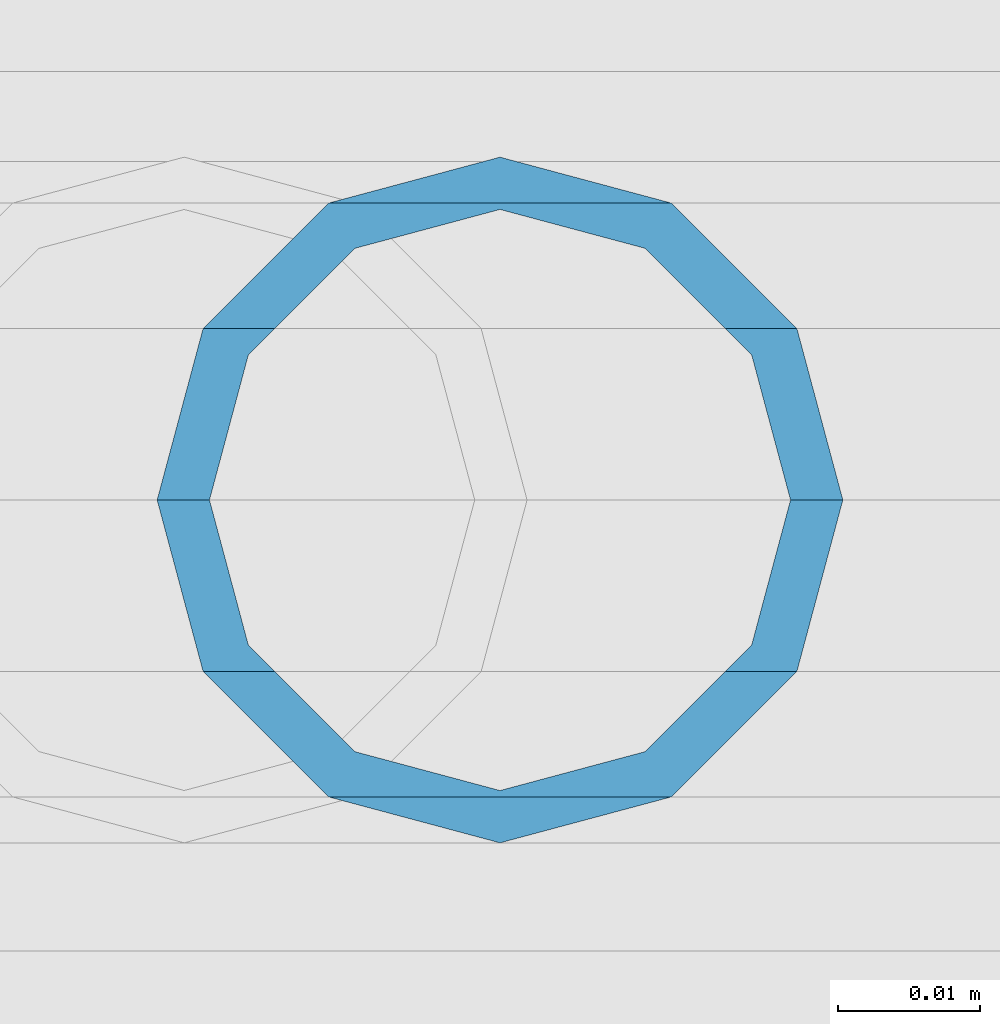
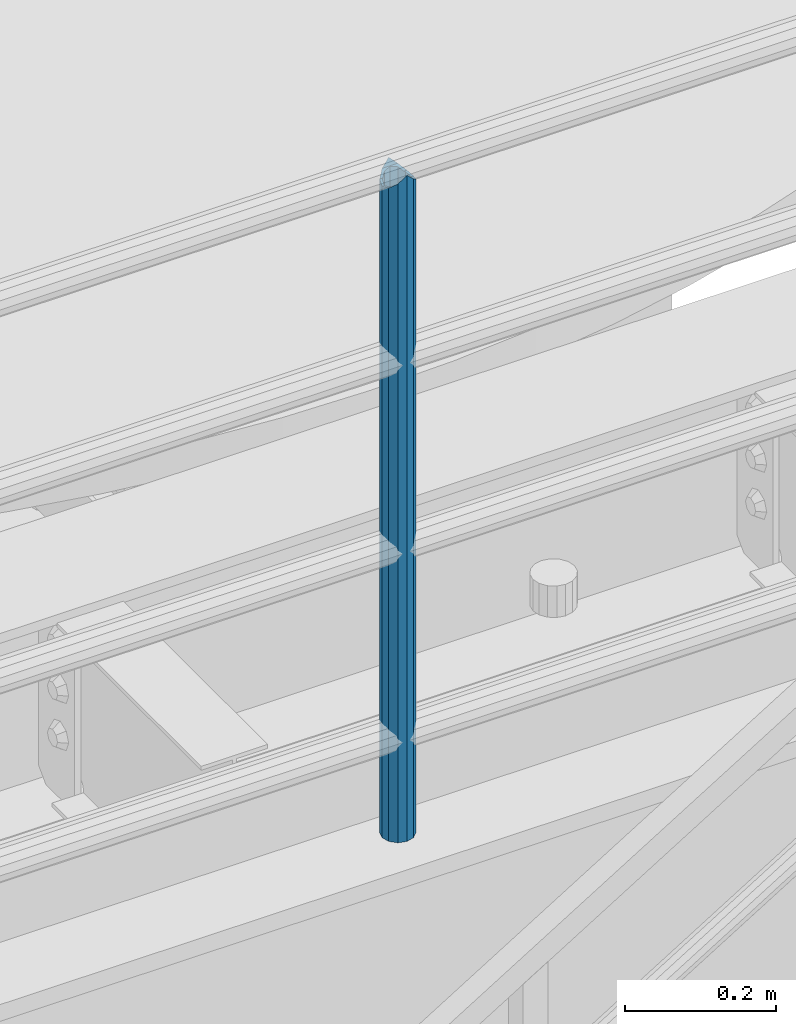
# One storey, part 631 of 1876: 1 column, 1 element without a shape of its own.
"""IFC2X3 building model written with IfcOpenShell, lengths in millimetres."""

from ifc_helpers import new_model, si_unit, frame, origin_with_axes, place, context, subcontext, project, spatial, faceted_brep, material, type_object, element, aggregate, save


model = new_model("IFC2X3")

# Units and contexts
model_context = context("Model", 3, precision=1e-05, world=origin_with_axes())
body_context = subcontext(model_context, "Body", "Model", "MODEL_VIEW")
ifc_project = project(units=[si_unit("LENGTHUNIT", "METRE", prefix="MILLI"), si_unit("AREAUNIT", "SQUARE_METRE"), si_unit("VOLUMEUNIT", "CUBIC_METRE"), si_unit("MASSUNIT", "GRAM", prefix="KILO"), si_unit("TIMEUNIT", "SECOND"), si_unit("PLANEANGLEUNIT", "RADIAN"), si_unit("SOLIDANGLEUNIT", "STERADIAN"), si_unit("THERMODYNAMICTEMPERATUREUNIT", "DEGREE_CELSIUS"), si_unit("LUMINOUSINTENSITYUNIT", "LUMEN")], contexts=[model_context])

# Site, building, storey
site_placement = place(None, origin_with_axes())
site = spatial("IfcSite", under=ifc_project, at=site_placement, CompositionType="ELEMENT")
building_placement = place(site_placement, origin_with_axes())
building = spatial("IfcBuilding", under=site, at=building_placement, Name="Undefined", CompositionType="ELEMENT")
storey_placement = place(building_placement, origin_with_axes())
storey = spatial("IfcBuildingStorey", under=building, at=storey_placement, Name="Undefined", CompositionType="ELEMENT", Elevation=0.0)

# Assembly, column
assembly_placement = place(storey_placement, origin_with_axes())
assembly = element("IfcElementAssembly", 1, at=assembly_placement, inside=storey, Name="RAIL", AssemblyPlace="NOTDEFINED", PredefinedType="RIGID_FRAME")
ifc_material = material()
column_type = type_object("IfcColumnType", Name="PIPE1-1/2SCH40", PredefinedType="NOTDEFINED")
column_placement = place(assembly_placement, frame((3959.22499997645, -4654.55000114554, 13309.6), z_axis=(0.0, 1.0, 0.0), x_axis=(0.0, 0.0, 1.0)))
column = element("IfcColumn", 2, at=column_placement, type_object=column_type, material=ifc_material, Name="POST", ObjectType="PIPE1-1/2SCH40", context=body_context, shape_type="Brep", body=[
    faceted_brep([(1076.325, 0.0, -24.1300000000001), (1064.26, 12.065, -20.8971929933186), (1064.26, -12.0650000000001, -20.8971929933186), (1054.93437856882, 17.7076214311801, 10.2235000000001), (1052.195, 20.4470000000001, 0.0), (1052.195, 24.13, 0.0), (1055.42780700668, 20.8971929933185, 12.0649999999996), (1055.42780700668, 15.8661214311869, 12.0649999999932), (1055.42780700668, 15.8661214311742, -12.065000000006), (1055.42780700668, 20.8971929933185, -12.0649999999996), (1054.93437856882, 17.7076214311801, -10.2235000000001), (1061.07042843786, 10.2235000000001, -17.7076214311801), (1063.80980700668, 0.0, -20.4470000000001), (1061.07042843786, -10.2235000000001, -17.7076214311801), (1055.42780700668, -15.8661214311742, -12.065000000006), (1055.42780700668, -20.8971929933184, -12.0649999999996), (1054.93437856882, -17.7076214311801, -10.2235000000001), (1052.195, -20.4470000000001, 0.0), (1052.195, -24.1300000000001, 0.0), (1054.93437856882, -17.7076214311801, 10.2235000000001), (1055.42780700668, -15.8661214311869, 12.0649999999932), (1055.42780700668, -20.8971929933184, 12.0649999999996), (1076.325, 0.0, 24.1300000000001), (1064.26, -12.0650000000001, 20.8971929933186), (1064.26, 12.065, 20.8971929933186), (1061.07042843787, -10.2235000000001, 17.7076214311801), (1063.80980700669, 0.0, 20.4470000000001), (1061.07042843787, 10.2235000000001, 17.7076214311801), (0.0, -20.8971929933184, -12.0649999999996), (0.0, -12.0650000000001, -20.8971929933186), (-1.45519152283669e-11, 0.0, -24.130000000001), (0.0, 12.0650000000001, -20.8971929933186), (0.0, 20.8971929933184, -12.0649999999996), (0.0, 24.1299999999992, 0.0), (0.0, 20.8971929933184, 12.0649999999996), (0.0, 12.0650000000001, 20.8971929933186), (-1.45519152283669e-11, 0.0, 24.130000000001), (0.0, -20.8971929933184, 12.0649999999996), (0.0, -24.1299999999992, 0.0), (0.0, -12.0650000000001, 20.8971929933186), (0.0, -17.7076214311803, -10.2235000000001), (0.0, -10.2235000000001, -17.7076214311801), (-1.45519152283669e-11, 0.0, -20.4470000000001), (0.0, 10.2235000000001, -17.7076214311801), (0.0, 17.7076214311803, -10.2235000000001), (0.0, 20.4469999999999, 0.0), (0.0, 17.7076214311803, 10.2235000000001), (0.0, 10.2235000000001, 17.7076214311801), (-1.45519152283669e-11, 0.0, 20.4470000000001), (0.0, -10.2235000000001, 17.7076214311801), (0.0, -17.7076214311803, 10.2235000000001), (0.0, -20.4469999999999, 0.0)], [[[0, 1, 2]], [[3, 4, 5, 6, 7]], [[8, 9, 5, 4, 10]], [[2, 1, 9, 8, 11, 12, 13, 14, 15]], [[15, 14, 16, 17, 18]], [[18, 17, 19, 20, 21]], [[22, 23, 24]], [[21, 20, 25, 26, 27, 7, 6, 24, 23]], [[28, 29, 2, 15]], [[29, 30, 0, 2]], [[30, 31, 1, 0]], [[31, 32, 9, 1]], [[32, 33, 5, 9]], [[33, 34, 6, 5]], [[34, 35, 24, 6]], [[35, 36, 22, 24]], [[37, 38, 18, 21]], [[39, 37, 21, 23]], [[36, 39, 23, 22]], [[38, 28, 15, 18]], [[37, 39, 36, 35, 34, 33, 32, 31, 30, 29, 28, 38], [40, 41, 42, 43, 44, 45, 46, 47, 48, 49, 50, 51]], [[49, 48, 26, 25]], [[19, 50, 49, 25, 20]], [[51, 50, 19, 17]], [[40, 51, 17, 16]], [[41, 40, 16, 14, 13]], [[42, 41, 13, 12]], [[43, 42, 12, 11]], [[10, 44, 43, 11, 8]], [[45, 44, 10, 4]], [[46, 45, 4, 3]], [[47, 46, 3, 7, 27]], [[48, 47, 27, 26]]]),
])
aggregate(assembly, [column])

save(model, "model.ifc")
